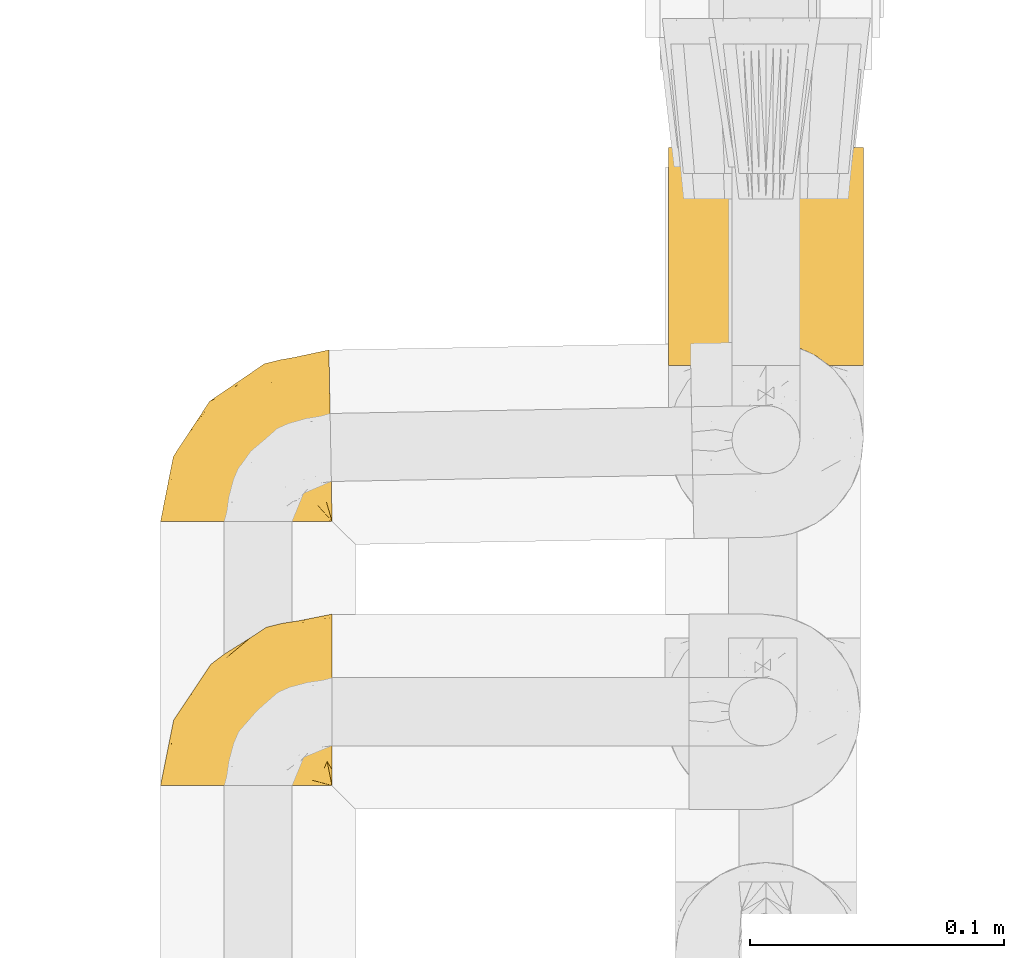
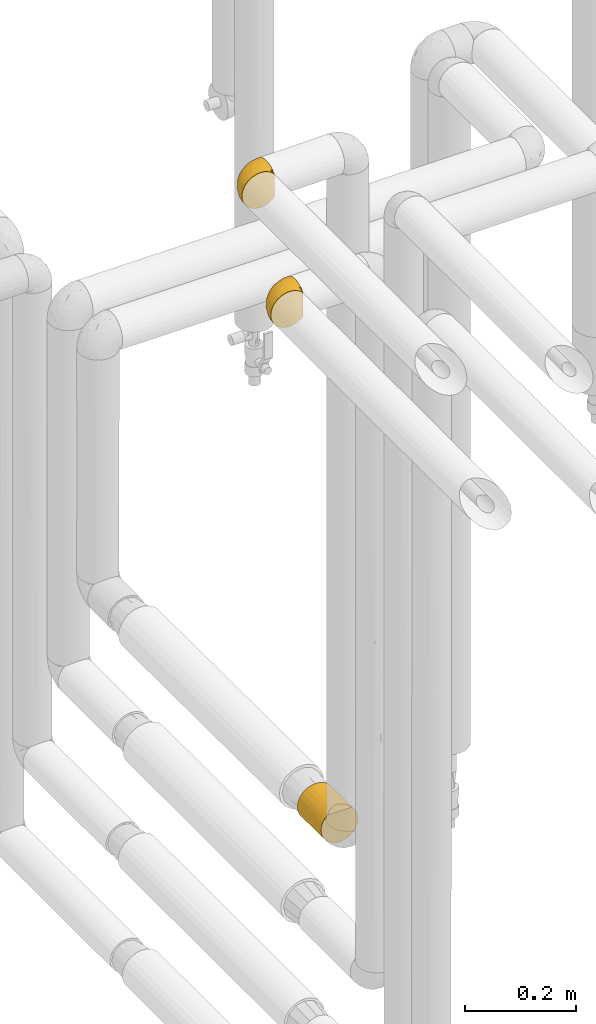
# One storey, part 70 of 827: 3 coverings.
"""IFC2X3 building model written with IfcOpenShell, lengths in millimetres."""

from ifc_helpers import new_model, entity, si_unit, converted_unit, derived_unit, direction, frame, origin, place, context, subcontext, project, spatial, faceted_brep, element, save


model = new_model("IFC2X3")

# Units and contexts
model_context = context("Model", 3, precision=0.01, world=origin(), true_north=direction((6.12303176911189e-17, 1.0)))
body_context = subcontext(model_context, "Body", "Model", "MODEL_VIEW")
ifc_project = project(units=[si_unit("LENGTHUNIT", "METRE", prefix="MILLI"), si_unit("AREAUNIT", "SQUARE_METRE"), si_unit("VOLUMEUNIT", "CUBIC_METRE"), converted_unit("PLANEANGLEUNIT", "DEGREE", entity("IfcRatioMeasure", 0.0174532925199433), si_unit("PLANEANGLEUNIT", "RADIAN"), dimensions=[0, 0, 0, 0, 0, 0, 0]), si_unit("MASSUNIT", "GRAM", prefix="KILO"), derived_unit("MASSDENSITYUNIT", [(si_unit("MASSUNIT", "GRAM", prefix="KILO"), 1), (si_unit("LENGTHUNIT", "METRE"), -3)]), derived_unit("MOMENTOFINERTIAUNIT", [(si_unit("LENGTHUNIT", "METRE"), 4)]), si_unit("TIMEUNIT", "SECOND"), si_unit("FREQUENCYUNIT", "HERTZ"), si_unit("THERMODYNAMICTEMPERATUREUNIT", "DEGREE_CELSIUS"), derived_unit("THERMALTRANSMITTANCEUNIT", [(si_unit("MASSUNIT", "GRAM", prefix="KILO"), 1), (si_unit("THERMODYNAMICTEMPERATUREUNIT", "KELVIN"), -1), (si_unit("TIMEUNIT", "SECOND"), -3)]), derived_unit("VOLUMETRICFLOWRATEUNIT", [(si_unit("LENGTHUNIT", "METRE"), 3), (si_unit("TIMEUNIT", "SECOND"), -1)]), derived_unit("MASSFLOWRATEUNIT", [(si_unit("MASSUNIT", "GRAM", prefix="KILO"), 1), (si_unit("TIMEUNIT", "SECOND"), -1)]), derived_unit("ROTATIONALFREQUENCYUNIT", [(si_unit("TIMEUNIT", "SECOND"), -1)]), si_unit("ELECTRICCURRENTUNIT", "AMPERE"), si_unit("ELECTRICVOLTAGEUNIT", "VOLT"), si_unit("POWERUNIT", "WATT"), si_unit("FORCEUNIT", "NEWTON", prefix="KILO"), si_unit("ILLUMINANCEUNIT", "LUX"), si_unit("LUMINOUSFLUXUNIT", "LUMEN"), si_unit("LUMINOUSINTENSITYUNIT", "CANDELA"), derived_unit("USERDEFINED", [(si_unit("MASSUNIT", "GRAM", prefix="KILO"), -1), (si_unit("LENGTHUNIT", "METRE"), -2), (si_unit("TIMEUNIT", "SECOND"), 3), (si_unit("LUMINOUSFLUXUNIT", "LUMEN"), 1)]), derived_unit("LINEARVELOCITYUNIT", [(si_unit("LENGTHUNIT", "METRE"), 1), (si_unit("TIMEUNIT", "SECOND"), -1)]), si_unit("PRESSUREUNIT", "PASCAL"), derived_unit("USERDEFINED", [(si_unit("LENGTHUNIT", "METRE"), -2), (si_unit("MASSUNIT", "GRAM", prefix="KILO"), 1), (si_unit("TIMEUNIT", "SECOND"), -2)]), derived_unit("LINEARFORCEUNIT", [(si_unit("MASSUNIT", "GRAM", prefix="KILO"), 1), (si_unit("LENGTHUNIT", "METRE"), 1), (si_unit("TIMEUNIT", "SECOND"), -2), (si_unit("LENGTHUNIT", "METRE"), -1)]), derived_unit("PLANARFORCEUNIT", [(si_unit("MASSUNIT", "GRAM", prefix="KILO"), 1), (si_unit("LENGTHUNIT", "METRE"), 1), (si_unit("TIMEUNIT", "SECOND"), -2), (si_unit("LENGTHUNIT", "METRE"), -2)])], contexts=[model_context])

# Site, building, storey
site_placement = place(None, origin())
site = spatial("IfcSite", under=ifc_project, at=site_placement, CompositionType="ELEMENT")
building_placement = place(site_placement, origin())
building = spatial("IfcBuilding", under=site, at=building_placement, CompositionType="ELEMENT")
storey_placement = place(building_placement, frame((0.0, 0.0, 28200.0)))
storey = spatial("IfcBuildingStorey", under=building, at=storey_placement, Name="08", CompositionType="ELEMENT", Elevation=28200.0)

# Coverings
covering_1_placement = place(storey_placement, frame((17888.53, 10890.94, 1308.25)))
element("IfcCovering", 1, at=covering_1_placement, inside=storey, Name=":ADSK_", ObjectType=":ADSK_", PredefinedType="INSULATION", context=body_context, shape_type="Brep", body=[
    faceted_brep([(20.8, 1.6, 6.74), (30.06, 1.6, 2.9), (40.0, 1.6, 1.6), (49.93, 1.6, 2.9), (59.2, 1.6, 6.74), (67.15, 1.6, 12.84), (73.25, 1.6, 20.8), (77.09, 1.6, 30.06), (78.4, 1.6, 40.0), (77.51, 1.6, 48.2), (74.9, 1.6, 56.01), (70.68, 1.6, 63.08), (65.05, 1.6, 69.1), (14.94, 1.6, 69.1), (9.31, 1.6, 63.08), (5.09, 1.6, 56.01), (2.48, 1.6, 48.2), (1.6, 1.6, 40.0), (2.9, 1.6, 30.06), (6.74, 1.6, 20.8), (12.84, 1.6, 12.84), (20.8, 87.5, 6.74), (12.84, 87.5, 12.84), (6.74, 87.5, 20.8), (2.9, 87.5, 30.06), (1.6, 87.5, 40.0), (2.9, 87.5, 49.93), (6.74, 87.5, 59.2), (12.84, 87.5, 67.15), (20.8, 87.5, 73.25), (30.06, 87.5, 77.09), (40.0, 87.5, 78.4), (49.93, 87.5, 77.09), (59.2, 87.5, 73.25), (67.15, 87.5, 67.15), (73.25, 87.5, 59.2), (77.09, 87.5, 49.93), (78.4, 87.5, 40.0), (77.09, 87.5, 30.06), (73.25, 87.5, 20.8), (67.15, 87.5, 12.84), (59.2, 87.5, 6.74), (49.93, 87.5, 2.9), (40.0, 87.5, 1.6), (30.06, 87.5, 2.9), (53.36, 8.5, 76.0), (46.78, 10.29, 77.79), (40.0, 10.9, 78.4), (59.51, 5.57, 73.07), (33.21, 10.29, 77.79), (26.63, 8.5, 76.0), (20.48, 5.57, 73.07)], [[[0, 1, 2, 3, 4, 5, 6, 7, 8, 9, 10, 11, 12, 13, 14, 15, 16, 17, 18, 19, 20]], [[21, 22, 23, 24, 25, 26, 27, 28, 29, 30, 31, 32, 33, 34, 35, 36, 37, 38, 39, 40, 41, 42, 43, 44]], [[24, 23, 19, 18]], [[25, 24, 18, 17]], [[23, 22, 20, 19]], [[1, 0, 21, 44]], [[2, 1, 44, 43]], [[22, 21, 0, 20]], [[3, 2, 43, 42]], [[4, 3, 42, 41]], [[41, 40, 5, 4]], [[7, 6, 39, 38]], [[8, 7, 38, 37]], [[40, 39, 6, 5]], [[9, 37, 36]], [[10, 36, 35]], [[11, 35, 34]], [[8, 37, 9]], [[9, 36, 10]], [[35, 11, 10]], [[34, 12, 11]], [[45, 33, 32]], [[32, 31, 46]], [[47, 46, 31]], [[48, 12, 33]], [[46, 45, 32]], [[48, 33, 45]], [[33, 12, 34]], [[49, 47, 31]], [[49, 31, 30]], [[50, 30, 29]], [[50, 49, 30]], [[13, 51, 29]], [[50, 29, 51]], [[29, 28, 13]], [[14, 28, 27]], [[15, 27, 26]], [[16, 26, 25]], [[14, 27, 15]], [[15, 26, 16]], [[25, 17, 16]], [[28, 14, 13]], [[45, 46, 47, 49, 50, 51, 13, 12, 48]]]),
])
covering_2_placement = place(storey_placement, frame((17688.48, 10829.62, 2810.08)))
element("IfcCovering", 2, at=covering_2_placement, inside=storey, Name=":ADSK_", ObjectType=":ADSK_", PredefinedType="INSULATION", context=body_context, shape_type="Brep", body=[
    faceted_brep([(62.89, 1.6, 70.97), (55.87, 1.6, 75.09), (48.14, 1.6, 77.64), (40.05, 1.6, 78.5), (31.49, 1.6, 77.53), (23.36, 1.6, 74.69), (16.07, 1.6, 70.11), (9.98, 1.6, 64.02), (5.4, 1.6, 56.73), (2.56, 1.6, 48.6), (1.6, 1.6, 40.05), (2.56, 1.6, 31.49), (5.4, 1.6, 23.36), (9.99, 1.6, 16.07), (16.07, 1.6, 9.98), (23.36, 1.6, 5.4), (31.49, 1.6, 2.56), (40.04, 1.6, 1.6), (48.14, 1.6, 2.46), (55.87, 1.6, 5.01), (62.9, 1.6, 9.12), (68.89, 1.6, 14.62), (68.89, 1.6, 16.82), (68.89, 1.6, 18.55), (68.89, 1.6, 20.52), (68.89, 1.6, 22.49), (68.89, 1.6, 24.45), (68.89, 1.6, 26.42), (68.89, 1.6, 28.39), (68.89, 1.6, 30.35), (68.89, 1.6, 32.55), (68.89, 1.6, 34.74), (68.89, 1.6, 36.94), (68.89, 1.6, 39.13), (68.89, 1.6, 41.33), (68.89, 1.6, 43.52), (68.89, 1.6, 45.71), (68.89, 1.6, 47.91), (68.89, 1.6, 50.1), (68.89, 1.6, 52.3), (68.89, 1.6, 54.49), (68.89, 1.6, 56.69), (68.89, 1.6, 58.88), (68.9, 1.6, 61.08), (68.9, 1.6, 63.27), (68.9, 1.6, 65.46), (69.14, 1.85, 14.62), (69.03, 7.85, 9.12), (68.9, 14.87, 5.0), (68.76, 22.6, 2.46), (68.61, 30.7, 1.6), (68.43, 40.65, 2.91), (68.26, 49.92, 6.75), (68.12, 57.88, 12.86), (68.01, 63.99, 20.82), (67.94, 67.83, 30.1), (67.92, 69.14, 40.05), (67.94, 67.83, 50.0), (68.01, 63.99, 59.27), (68.13, 57.88, 67.24), (68.27, 49.91, 73.35), (68.44, 40.64, 77.19), (68.62, 30.69, 78.5), (68.77, 22.6, 77.63), (68.91, 14.87, 75.09), (69.04, 7.85, 70.97), (69.14, 1.85, 65.46), (69.14, 1.85, 63.27), (69.14, 1.85, 62.29), (69.14, 1.85, 60.7), (69.14, 1.85, 59.11), (69.14, 1.85, 57.52), (69.14, 1.85, 55.93), (69.14, 1.85, 54.34), (69.14, 1.85, 52.75), (69.14, 1.85, 51.16), (69.14, 1.85, 49.58), (69.14, 1.85, 47.99), (69.14, 1.85, 46.4), (69.14, 1.85, 44.81), (69.14, 1.85, 43.22), (69.14, 1.85, 41.63), (69.14, 1.85, 40.04), (69.14, 1.85, 38.45), (69.14, 1.85, 36.87), (69.14, 1.85, 35.28), (69.14, 1.85, 33.69), (69.14, 1.85, 32.1), (69.14, 1.85, 30.51), (69.14, 1.85, 28.92), (69.14, 1.85, 27.33), (69.14, 1.85, 25.37), (69.14, 1.85, 23.4), (69.14, 1.85, 21.2), (69.14, 1.85, 19.01), (69.14, 1.85, 16.82), (68.96, 1.77, 42.33), (68.97, 1.78, 44.01), (68.97, 1.78, 45.71), (68.97, 1.78, 47.19), (68.95, 1.77, 23.63), (68.96, 1.77, 25.15), (68.98, 1.78, 61.34), (68.97, 1.79, 22.09), (68.97, 1.78, 29.72), (68.98, 1.79, 56.73), (68.97, 1.78, 55.16), (68.97, 1.78, 37.66), (68.94, 1.74, 64.12), (68.97, 1.79, 28.13), (68.97, 1.78, 26.64), (68.96, 1.77, 31.43), (68.96, 1.78, 16.15), (68.97, 1.78, 40.79), (68.97, 1.79, 39.29), (68.97, 1.78, 50.45), (68.96, 1.78, 17.69), (68.96, 1.77, 19.15), (68.97, 1.77, 62.78), (68.97, 1.78, 58.38), (68.96, 1.77, 59.9), (68.97, 1.77, 65.46), (68.95, 1.72, 65.46), (68.92, 1.66, 65.46), (68.96, 1.78, 14.62), (69.02, 1.8, 14.62), (68.97, 1.79, 34.46), (68.97, 1.78, 32.95), (68.97, 1.78, 20.63), (68.96, 1.77, 53.51), (68.98, 1.78, 51.96), (68.96, 1.77, 48.83), (69.08, 1.82, 65.46), (68.92, 1.67, 14.62), (68.94, 1.72, 14.62), (68.96, 1.77, 35.99), (69.07, 1.82, 14.62), (66.88, 9.37, 7.84), (63.06, 17.56, 3.52), (64.47, 7.46, 8.24), (43.85, 16.0, 1.6), (52.06, 12.48, 2.63), (53.09, 7.39, 3.53), (61.45, 28.66, 1.6), (61.35, 13.61, 4.55), (57.66, 12.88, 3.86), (56.0, 19.11, 2.28), (62.89, 29.07, 1.6), (65.23, 9.11, 7.6), (62.85, 5.67, 8.24), (61.33, 3.72, 7.84), (41.95, 8.8, 1.6), (49.07, 21.31, 1.6), (54.29, 26.62, 1.6), (57.3, 8.24, 4.87), (41.56, 7.35, 1.6), (13.77, 37.74, 29.67), (5.81, 17.86, 27.35), (6.62, 27.16, 40.05), (58.22, 36.84, 2.4), (51.02, 33.94, 2.43), (60.79, 44.61, 4.52), (51.7, 41.8, 4.53), (48.39, 65.17, 32.88), (54.36, 66.22, 40.05), (20.19, 37.34, 18.02), (21.9, 45.75, 25.43), (12.61, 26.21, 19.59), (51.34, 63.72, 25.34), (4.27, 15.21, 40.05), (57.81, 60.12, 16.64), (54.67, 52.08, 9.54), (45.47, 56.3, 16.64), (41.71, 26.0, 2.36), (34.68, 22.53, 3.27), (28.66, 11.99, 3.75), (20.48, 10.96, 7.49), (14.63, 15.59, 12.86), (23.71, 21.38, 7.49), (28.82, 40.87, 12.86), (34.51, 38.81, 8.33), (27.85, 31.74, 8.53), (19.45, 28.04, 12.86), (8.6, 13.24, 19.59), (41.58, 45.46, 9.01), (23.02, 49.92, 32.49), (31.29, 54.92, 27.35), (31.7, 56.29, 40.05), (13.78, 38.05, 40.05), (20.95, 48.93, 40.05), (29.33, 48.62, 19.52), (40.95, 33.74, 4.1), (36.66, 49.06, 14.14), (42.45, 63.65, 40.05), (27.85, 31.75, 71.56), (34.69, 22.54, 76.82), (40.96, 33.74, 75.99), (48.39, 65.17, 47.22), (23.02, 49.91, 47.61), (13.76, 37.72, 50.43), (21.88, 45.72, 54.67), (31.27, 54.9, 52.76), (51.34, 63.72, 54.76), (57.82, 60.11, 63.46), (54.68, 52.07, 70.55), (23.71, 21.38, 72.6), (20.48, 10.95, 72.6), (28.66, 11.99, 76.34), (60.79, 44.61, 75.57), (58.23, 36.83, 77.7), (41.57, 7.34, 78.5), (29.31, 48.6, 60.58), (5.81, 17.86, 52.75), (20.19, 37.34, 62.07), (14.62, 15.59, 67.23), (12.61, 26.21, 60.5), (8.6, 13.24, 60.5), (19.45, 28.04, 67.23), (43.86, 15.99, 78.5), (51.03, 33.93, 77.66), (54.3, 26.62, 78.5), (41.58, 45.45, 71.08), (51.71, 41.79, 75.57), (41.96, 8.79, 78.5), (45.48, 56.3, 63.46), (61.46, 28.65, 78.5), (62.9, 29.06, 78.5), (28.82, 40.88, 67.23), (36.68, 49.07, 65.95), (41.72, 26.0, 77.74), (49.08, 21.31, 78.5), (34.51, 38.82, 71.76), (63.07, 17.55, 76.57), (66.89, 9.34, 72.23), (69.02, 1.8, 65.46), (63.47, 7.9, 72.5), (63.21, 6.16, 71.85), (53.08, 7.38, 76.57), (57.96, 18.47, 77.46), (61.43, 12.46, 75.11), (65.34, 7.76, 71.68), (61.34, 3.72, 72.25), (57.67, 12.87, 76.23), (51.4, 14.42, 77.81), (57.0, 9.16, 75.54), (61.57, 5.37, 72.49)], [[[0, 1, 2, 3, 4, 5, 6, 7, 8, 9, 10, 11, 12, 13, 14, 15, 16, 17, 18, 19, 20, 21, 22, 23, 24, 25, 26, 27, 28, 29, 30, 31, 32, 33, 34, 35, 36, 37, 38, 39, 40, 41, 42, 43, 44, 45]], [[46, 47, 48, 49, 50, 51, 52, 53, 54, 55, 56, 57, 58, 59, 60, 61, 62, 63, 64, 65, 66, 67, 68, 69, 70, 71, 72, 73, 74, 75, 76, 77, 78, 79, 80, 81, 82, 83, 84, 85, 86, 87, 88, 89, 90, 91, 92, 93, 94, 95]], [[96, 97, 35]], [[98, 99, 36]], [[100, 101, 26]], [[69, 68, 102]], [[25, 24, 103]], [[29, 28, 104]], [[25, 103, 100]], [[72, 105, 106]], [[84, 83, 107]], [[89, 88, 104]], [[108, 67, 66]], [[109, 110, 90]], [[111, 29, 104]], [[112, 22, 21]], [[113, 114, 82]], [[109, 28, 27]], [[115, 39, 38]], [[105, 41, 106]], [[111, 30, 29]], [[23, 116, 117]], [[97, 96, 80]], [[67, 108, 118]], [[105, 71, 119]], [[98, 36, 97]], [[102, 120, 69]], [[108, 121, 122, 123, 45]], [[112, 95, 116]], [[22, 116, 23]], [[94, 117, 116]], [[118, 68, 67]], [[43, 118, 44]], [[112, 124, 125]], [[22, 112, 116]], [[70, 120, 119]], [[44, 118, 108]], [[120, 43, 42]], [[120, 42, 119]], [[120, 70, 69]], [[126, 127, 86]], [[117, 94, 128]], [[118, 43, 102]], [[129, 130, 74]], [[77, 131, 99]], [[116, 95, 94]], [[44, 108, 45]], [[108, 66, 132]], [[95, 112, 46]], [[112, 21, 133, 134, 124]], [[105, 72, 71]], [[119, 42, 41]], [[71, 70, 119]], [[40, 106, 41]], [[41, 105, 119]], [[40, 129, 106]], [[74, 73, 129]], [[106, 129, 73]], [[131, 115, 38]], [[129, 40, 39]], [[73, 72, 106]], [[75, 74, 130]], [[115, 75, 130]], [[130, 39, 115]], [[39, 130, 129]], [[115, 76, 75]], [[76, 115, 131]], [[77, 99, 78]], [[37, 131, 38]], [[77, 76, 131]], [[37, 36, 99]], [[98, 78, 99]], [[37, 99, 131]], [[80, 79, 97]], [[79, 98, 97]], [[79, 78, 98]], [[113, 96, 34]], [[36, 35, 97]], [[113, 34, 33]], [[81, 80, 96]], [[34, 96, 35]], [[96, 113, 81]], [[82, 81, 113]], [[33, 114, 113]], [[84, 107, 135]], [[107, 32, 135]], [[114, 33, 107]], [[32, 107, 33]], [[126, 86, 85]], [[135, 32, 31]], [[114, 83, 82]], [[83, 114, 107]], [[85, 84, 135]], [[109, 89, 104]], [[89, 109, 90]], [[111, 87, 127]], [[127, 126, 31]], [[88, 111, 104]], [[30, 111, 127]], [[27, 110, 109]], [[28, 109, 104]], [[110, 91, 90]], [[100, 92, 101]], [[110, 27, 101]], [[91, 110, 101]], [[117, 24, 23]], [[111, 88, 87]], [[103, 24, 128]], [[30, 127, 31]], [[86, 127, 87]], [[126, 135, 31]], [[135, 126, 85]], [[120, 102, 43]], [[118, 102, 68]], [[91, 101, 92]], [[26, 101, 27]], [[93, 92, 103]], [[100, 26, 25]], [[100, 103, 92]], [[128, 93, 103]], [[93, 128, 94]], [[128, 24, 117]], [[136, 137, 47]], [[48, 137, 138]], [[139, 125, 124]], [[140, 141, 142]], [[143, 49, 138]], [[144, 139, 145]], [[48, 138, 49]], [[138, 144, 146]], [[49, 143, 147, 50]], [[136, 125, 148]], [[19, 18, 142]], [[149, 145, 139]], [[148, 139, 144]], [[133, 150, 149]], [[150, 19, 142]], [[21, 20, 133]], [[18, 151, 142]], [[124, 149, 139]], [[141, 152, 145]], [[19, 150, 20]], [[20, 150, 133]], [[47, 46, 136]], [[138, 153, 143]], [[137, 48, 47]], [[125, 139, 148]], [[149, 124, 134, 133]], [[141, 154, 142]], [[144, 145, 146]], [[148, 138, 137]], [[146, 152, 153]], [[152, 146, 145]], [[138, 146, 153]], [[138, 148, 144]], [[148, 137, 136]], [[18, 17, 155, 151]], [[151, 140, 142]], [[150, 142, 154]], [[152, 141, 140]], [[154, 145, 149]], [[145, 154, 141]], [[150, 154, 149]], [[156, 157, 158]], [[159, 153, 160]], [[161, 52, 51]], [[162, 161, 159]], [[55, 163, 164]], [[165, 156, 166]], [[155, 17, 16]], [[167, 157, 156]], [[163, 55, 168]], [[157, 11, 169]], [[170, 54, 53]], [[53, 52, 171]], [[168, 55, 54]], [[54, 170, 168]], [[170, 171, 172]], [[152, 173, 160]], [[174, 140, 175]], [[155, 16, 175]], [[176, 177, 178]], [[177, 14, 13]], [[175, 140, 151, 155]], [[175, 16, 15]], [[176, 175, 15]], [[179, 180, 181]], [[175, 178, 174]], [[182, 177, 167]], [[179, 182, 165]], [[177, 182, 178]], [[13, 12, 183]], [[157, 12, 11]], [[158, 157, 169]], [[167, 183, 157]], [[172, 171, 184]], [[183, 177, 13]], [[185, 186, 166]], [[14, 176, 15]], [[187, 186, 185]], [[185, 188, 189]], [[165, 190, 179]], [[51, 50, 147]], [[161, 171, 52]], [[184, 171, 162]], [[172, 186, 168]], [[184, 191, 180]], [[178, 182, 181]], [[174, 191, 173]], [[11, 10, 169]], [[157, 183, 12]], [[177, 183, 167]], [[177, 176, 14]], [[175, 176, 178]], [[191, 184, 162]], [[179, 190, 192]], [[160, 162, 159]], [[174, 178, 181]], [[164, 163, 193]], [[164, 56, 55]], [[186, 163, 168]], [[165, 182, 167]], [[174, 173, 140]], [[181, 182, 179]], [[167, 156, 165]], [[190, 166, 186]], [[186, 172, 190]], [[192, 184, 180]], [[179, 192, 180]], [[174, 181, 191]], [[165, 166, 190]], [[188, 185, 156]], [[156, 185, 166]], [[193, 163, 187]], [[185, 189, 187]], [[163, 186, 187]], [[191, 181, 180]], [[190, 172, 192]], [[172, 184, 192]], [[159, 51, 147]], [[171, 161, 162]], [[51, 159, 161]], [[159, 147, 143, 153]], [[152, 160, 153]], [[191, 162, 160]], [[171, 170, 53]], [[168, 170, 172]], [[156, 158, 188]], [[160, 173, 191]], [[140, 173, 152]], [[194, 195, 196]], [[193, 197, 164]], [[198, 199, 200]], [[201, 202, 197]], [[59, 203, 204]], [[187, 189, 198]], [[205, 206, 207]], [[5, 4, 207]], [[61, 208, 209]], [[4, 210, 207]], [[59, 204, 60]], [[4, 3, 210]], [[164, 197, 57]], [[208, 61, 60]], [[200, 211, 201]], [[58, 57, 202]], [[158, 212, 199]], [[213, 211, 200]], [[214, 215, 216]], [[7, 6, 214]], [[203, 59, 58]], [[212, 8, 216]], [[212, 169, 9]], [[6, 5, 206]], [[207, 206, 5]], [[8, 212, 9]], [[215, 214, 217]], [[205, 207, 195]], [[207, 218, 195]], [[209, 219, 220]], [[204, 221, 222]], [[206, 214, 6]], [[199, 212, 215]], [[217, 214, 205]], [[213, 215, 217]], [[8, 7, 216]], [[198, 188, 199]], [[207, 210, 223, 218]], [[203, 202, 224]], [[209, 220, 225, 226]], [[226, 62, 61]], [[201, 224, 202]], [[211, 227, 228]], [[208, 204, 222]], [[229, 218, 230]], [[196, 222, 221]], [[169, 212, 158]], [[169, 10, 9]], [[214, 206, 205]], [[214, 216, 7]], [[212, 216, 215]], [[224, 221, 204]], [[217, 194, 227]], [[231, 227, 194]], [[195, 229, 196]], [[57, 56, 164]], [[201, 187, 198]], [[57, 197, 202]], [[194, 217, 205]], [[219, 230, 220]], [[213, 217, 227]], [[195, 194, 205]], [[231, 221, 228]], [[213, 227, 211]], [[199, 215, 213]], [[227, 231, 228]], [[224, 201, 211]], [[198, 200, 201]], [[213, 200, 199]], [[197, 187, 201]], [[218, 229, 195]], [[187, 197, 193]], [[194, 196, 231]], [[196, 221, 231]], [[221, 224, 228]], [[224, 211, 228]], [[204, 208, 60]], [[209, 208, 222]], [[209, 222, 219]], [[61, 209, 226]], [[222, 196, 219]], [[219, 196, 229]], [[202, 203, 58]], [[204, 203, 224]], [[188, 198, 189]], [[188, 158, 199]], [[219, 229, 230]], [[63, 225, 232]], [[225, 220, 232]], [[63, 62, 226, 225]], [[233, 64, 232]], [[121, 234, 235]], [[236, 122, 121]], [[237, 218, 223]], [[63, 232, 64]], [[132, 66, 65]], [[232, 238, 239]], [[237, 223, 2]], [[240, 132, 233]], [[233, 132, 65]], [[1, 237, 2]], [[220, 238, 232]], [[0, 123, 241]], [[2, 223, 210, 3]], [[235, 234, 240]], [[238, 230, 242]], [[243, 237, 244]], [[245, 236, 244]], [[0, 45, 123]], [[123, 122, 245]], [[241, 1, 0]], [[1, 241, 237]], [[240, 239, 235]], [[244, 236, 242]], [[122, 236, 245]], [[244, 242, 243]], [[245, 237, 241]], [[243, 230, 218]], [[230, 243, 242]], [[237, 243, 218]], [[237, 245, 244]], [[245, 241, 123]], [[230, 238, 220]], [[239, 238, 242]], [[235, 242, 236]], [[232, 239, 240]], [[242, 235, 239]], [[121, 235, 236]], [[64, 233, 65]], [[132, 240, 234]], [[232, 240, 233]], [[112, 125, 136]], [[112, 136, 46]], [[108, 132, 234]], [[108, 234, 121]]]),
])
covering_3_placement = place(storey_placement, frame((17688.48, 10725.53, 2611.68)))
element("IfcCovering", 3, at=covering_3_placement, inside=storey, Name=":ADSK_", ObjectType=":ADSK_", PredefinedType="INSULATION", context=body_context, shape_type="Brep", body=[
    faceted_brep([(23.36, 1.6, 74.68), (16.07, 1.6, 70.1), (9.98, 1.6, 64.01), (5.4, 1.6, 56.72), (2.56, 1.6, 48.6), (1.6, 1.6, 40.05), (2.56, 1.6, 31.49), (5.41, 1.6, 23.36), (9.99, 1.6, 16.07), (16.08, 1.6, 9.98), (23.37, 1.6, 5.4), (31.49, 1.6, 2.56), (40.05, 1.6, 1.6), (48.15, 1.6, 2.46), (55.88, 1.6, 5.01), (62.9, 1.6, 9.13), (68.89, 1.6, 14.62), (68.89, 1.6, 16.82), (68.89, 1.6, 18.56), (68.89, 1.6, 20.52), (68.89, 1.6, 22.49), (68.89, 1.6, 24.46), (68.89, 1.6, 26.42), (68.89, 1.6, 28.39), (68.89, 1.6, 30.36), (68.89, 1.6, 32.55), (68.89, 1.6, 34.75), (68.89, 1.6, 36.94), (68.89, 1.6, 39.13), (68.89, 1.6, 41.33), (68.89, 1.6, 43.52), (68.89, 1.6, 45.72), (68.89, 1.6, 47.91), (68.89, 1.6, 50.11), (68.89, 1.6, 52.3), (68.89, 1.6, 54.49), (68.89, 1.6, 56.69), (68.89, 1.6, 58.88), (68.89, 1.6, 61.08), (68.89, 1.6, 63.27), (68.89, 1.6, 65.47), (62.89, 1.6, 70.97), (55.86, 1.6, 75.09), (48.13, 1.6, 77.64), (40.05, 1.6, 78.5), (31.49, 1.6, 77.53), (69.15, 1.85, 14.62), (69.15, 7.85, 9.12), (69.15, 14.87, 5.0), (69.15, 22.6, 2.46), (69.15, 30.7, 1.6), (69.15, 40.65, 2.91), (69.15, 49.92, 6.75), (69.15, 57.88, 12.86), (69.15, 63.99, 20.82), (69.15, 67.84, 30.09), (69.15, 69.15, 40.05), (69.15, 67.84, 50.0), (69.15, 63.99, 59.27), (69.15, 57.88, 67.23), (69.15, 49.92, 73.34), (69.15, 40.65, 77.19), (69.15, 30.7, 78.5), (69.15, 22.6, 77.63), (69.15, 14.87, 75.09), (69.15, 7.85, 70.97), (69.15, 1.85, 65.47), (69.15, 1.85, 63.27), (69.15, 1.85, 62.29), (69.15, 1.85, 60.7), (69.15, 1.85, 59.11), (69.15, 1.85, 57.52), (69.15, 1.85, 55.93), (69.15, 1.85, 54.34), (69.15, 1.85, 52.76), (69.15, 1.85, 51.17), (69.15, 1.85, 49.58), (69.15, 1.85, 47.99), (69.15, 1.85, 46.4), (69.15, 1.85, 44.81), (69.15, 1.85, 43.22), (69.15, 1.85, 41.63), (69.15, 1.85, 40.05), (69.15, 1.85, 38.46), (69.15, 1.85, 36.87), (69.15, 1.85, 35.28), (69.15, 1.85, 33.69), (69.15, 1.85, 32.1), (69.15, 1.85, 30.51), (69.15, 1.85, 28.92), (69.15, 1.85, 27.33), (69.15, 1.85, 25.37), (69.15, 1.85, 23.4), (69.15, 1.85, 21.21), (69.15, 1.85, 19.01), (69.15, 1.85, 16.82), (68.96, 1.77, 42.32), (68.97, 1.78, 44.02), (68.97, 1.77, 47.13), (68.97, 1.77, 48.74), (68.95, 1.76, 23.57), (68.96, 1.77, 25.13), (68.98, 1.79, 61.34), (68.97, 1.78, 22.02), (68.97, 1.78, 29.72), (68.98, 1.78, 56.73), (68.97, 1.78, 55.14), (68.97, 1.78, 37.66), (68.94, 1.74, 64.12), (68.98, 1.78, 28.13), (68.98, 1.78, 26.62), (68.96, 1.77, 31.46), (68.97, 1.78, 16.16), (68.98, 1.78, 39.16), (68.98, 1.78, 50.37), (68.97, 1.77, 17.69), (68.96, 1.77, 19.17), (68.97, 1.77, 62.78), (68.97, 1.78, 58.35), (68.98, 1.78, 45.53), (68.96, 1.77, 59.91), (68.97, 1.77, 65.47), (68.94, 1.72, 65.47), (68.92, 1.66, 65.47), (68.97, 1.77, 14.62), (69.02, 1.8, 14.62), (69.08, 1.82, 14.62), (68.98, 1.79, 20.59), (68.97, 1.78, 32.99), (68.98, 1.79, 34.48), (68.97, 1.78, 51.91), (69.08, 1.82, 65.47), (69.02, 1.8, 65.47), (68.96, 1.76, 53.48), (68.92, 1.66, 14.62), (68.94, 1.72, 14.62), (68.97, 1.78, 40.77), (68.96, 1.77, 35.97), (67.02, 9.41, 7.84), (63.33, 17.65, 3.53), (64.61, 7.41, 8.32), (49.27, 21.47, 1.6), (51.4, 15.21, 2.19), (43.94, 16.15, 1.6), (61.87, 28.75, 1.6), (61.54, 13.67, 4.57), (57.95, 12.79, 3.96), (56.12, 19.18, 2.28), (63.4, 29.16, 1.6), (65.41, 9.04, 7.69), (53.1, 7.41, 3.53), (63.04, 5.74, 8.32), (61.33, 3.72, 7.84), (41.99, 8.87, 1.6), (54.6, 26.8, 1.6), (56.6, 9.53, 4.34), (41.58, 7.34, 1.6), (13.72, 37.63, 29.63), (5.82, 17.92, 27.34), (6.74, 27.45, 40.05), (58.82, 37.01, 2.39), (51.58, 34.22, 2.43), (42.09, 45.87, 9.07), (46.12, 56.57, 16.64), (55.56, 52.31, 9.54), (52.38, 42.07, 4.52), (61.54, 44.74, 4.52), (23.76, 21.49, 7.49), (20.5, 11.02, 7.49), (14.64, 15.64, 12.85), (41.77, 26.02, 2.35), (16.28, 36.59, 22.66), (49.4, 65.49, 32.9), (52.34, 63.99, 25.33), (4.3, 15.2, 40.05), (58.67, 60.27, 16.64), (25.26, 45.25, 19.99), (20.17, 35.21, 16.37), (34.7, 22.52, 3.26), (28.67, 12.03, 3.75), (8.62, 13.32, 19.58), (33.37, 35.9, 7.5), (41.35, 33.87, 4.04), (17.15, 25.73, 13.94), (12.68, 26.34, 19.58), (21.47, 46.78, 28.21), (41.11, 59.54, 24.75), (37.53, 60.18, 31.42), (30.64, 53.93, 26.2), (26.66, 53.36, 33.36), (21.38, 49.36, 40.05), (14.06, 38.4, 40.05), (55.54, 66.44, 40.05), (35.17, 50.09, 16.14), (29.04, 41.08, 12.85), (24.34, 31.14, 10.47), (29.33, 28.19, 6.49), (43.3, 64.0, 40.05), (32.34, 56.68, 40.05), (57.75, 43.9, 75.57), (49.41, 65.46, 47.37), (27.85, 52.22, 52.91), (13.7, 37.61, 50.46), (14.63, 15.64, 67.23), (8.61, 13.31, 60.5), (48.85, 50.02, 70.55), (54.13, 59.28, 63.45), (37.84, 53.05, 62.61), (23.75, 21.48, 72.6), (20.49, 11.01, 72.6), (28.66, 12.03, 76.34), (20.83, 41.02, 59.34), (55.15, 35.39, 77.76), (54.6, 26.8, 78.5), (61.87, 28.75, 78.5), (41.58, 7.34, 78.5), (57.58, 65.81, 53.16), (59.91, 53.28, 70.55), (36.94, 59.8, 48.88), (45.72, 61.82, 54.76), (5.82, 17.91, 52.74), (37.91, 41.4, 71.93), (50.18, 40.48, 75.79), (12.67, 26.34, 60.5), (49.29, 31.68, 77.86), (42.64, 27.68, 77.64), (43.94, 16.15, 78.5), (49.27, 21.47, 78.5), (19.45, 28.05, 67.23), (34.7, 22.54, 76.82), (41.99, 8.87, 78.5), (62.29, 37.3, 77.8), (29.01, 41.07, 67.23), (31.47, 32.24, 73.2), (37.18, 47.4, 67.66), (43.45, 35.77, 75.99), (63.33, 17.65, 76.57), (67.23, 11.06, 73.21), (66.07, 8.55, 71.93), (65.22, 6.63, 71.07), (61.99, 12.77, 75.09), (57.95, 12.79, 76.13), (53.09, 7.41, 76.57), (56.84, 18.97, 77.69), (61.33, 3.72, 72.26), (63.06, 5.76, 71.77), (51.41, 15.21, 77.9), (56.61, 9.52, 75.75)], [[[0, 1, 2, 3, 4, 5, 6, 7, 8, 9, 10, 11, 12, 13, 14, 15, 16, 17, 18, 19, 20, 21, 22, 23, 24, 25, 26, 27, 28, 29, 30, 31, 32, 33, 34, 35, 36, 37, 38, 39, 40, 41, 42, 43, 44, 45]], [[46, 47, 48, 49, 50, 51, 52, 53, 54, 55, 56, 57, 58, 59, 60, 61, 62, 63, 64, 65, 66, 67, 68, 69, 70, 71, 72, 73, 74, 75, 76, 77, 78, 79, 80, 81, 82, 83, 84, 85, 86, 87, 88, 89, 90, 91, 92, 93, 94, 95]], [[96, 97, 30]], [[98, 77, 99]], [[100, 101, 21]], [[69, 68, 102]], [[20, 19, 103]], [[24, 23, 104]], [[20, 103, 100]], [[72, 105, 106]], [[84, 83, 107]], [[89, 88, 104]], [[108, 67, 66]], [[109, 110, 90]], [[111, 25, 24]], [[112, 17, 16]], [[82, 113, 83]], [[109, 23, 22]], [[114, 76, 75]], [[105, 36, 106]], [[104, 111, 24]], [[18, 115, 116]], [[97, 96, 80]], [[67, 108, 117]], [[105, 71, 118]], [[31, 97, 119]], [[102, 120, 69]], [[108, 121, 122, 123, 40]], [[112, 95, 115]], [[17, 115, 18]], [[94, 116, 115]], [[117, 68, 67]], [[38, 117, 39]], [[112, 124, 125, 126, 46]], [[17, 112, 115]], [[70, 120, 118]], [[39, 117, 108]], [[120, 38, 37]], [[120, 37, 118]], [[120, 70, 69]], [[116, 94, 127]], [[128, 86, 129]], [[117, 38, 102]], [[74, 130, 75]], [[99, 33, 32]], [[115, 95, 94]], [[39, 108, 40]], [[108, 66, 131, 132, 121]], [[105, 72, 71]], [[118, 37, 36]], [[71, 70, 118]], [[35, 106, 36]], [[36, 105, 118]], [[35, 133, 106]], [[74, 73, 133]], [[106, 133, 73]], [[99, 114, 33]], [[133, 35, 34]], [[73, 72, 106]], [[95, 112, 46]], [[112, 16, 134, 135, 124]], [[130, 114, 75]], [[99, 76, 114]], [[114, 130, 33]], [[34, 33, 130]], [[78, 77, 98]], [[98, 119, 78]], [[130, 133, 34]], [[133, 130, 74]], [[79, 97, 80]], [[98, 99, 32]], [[98, 32, 31]], [[77, 76, 99]], [[97, 79, 119]], [[136, 96, 29]], [[30, 97, 31]], [[136, 29, 28]], [[81, 80, 96]], [[29, 96, 30]], [[31, 119, 98]], [[119, 79, 78]], [[96, 136, 81]], [[82, 81, 136]], [[113, 107, 83]], [[84, 107, 137]], [[107, 27, 137]], [[113, 28, 107]], [[27, 107, 28]], [[85, 84, 137]], [[137, 27, 26]], [[113, 136, 28]], [[136, 113, 82]], [[109, 89, 104]], [[86, 85, 129]], [[89, 109, 90]], [[111, 87, 128]], [[26, 129, 137]], [[88, 111, 104]], [[25, 111, 128]], [[22, 110, 109]], [[23, 109, 104]], [[110, 91, 90]], [[100, 92, 101]], [[110, 22, 101]], [[91, 110, 101]], [[116, 19, 18]], [[111, 88, 87]], [[127, 103, 19]], [[25, 128, 26]], [[86, 128, 87]], [[128, 129, 26]], [[137, 129, 85]], [[120, 102, 38]], [[117, 102, 68]], [[91, 101, 92]], [[21, 101, 22]], [[93, 92, 103]], [[100, 21, 20]], [[100, 103, 92]], [[127, 93, 103]], [[93, 127, 94]], [[116, 127, 19]], [[126, 138, 47]], [[48, 138, 139]], [[140, 125, 124]], [[141, 142, 143]], [[144, 49, 139]], [[145, 140, 146]], [[48, 139, 49]], [[139, 145, 147]], [[49, 144, 148, 50]], [[126, 125, 149]], [[14, 13, 150]], [[151, 146, 140]], [[149, 140, 145]], [[152, 151, 135]], [[152, 14, 150]], [[16, 15, 134]], [[13, 153, 150]], [[124, 151, 140]], [[141, 147, 142]], [[14, 152, 15]], [[15, 152, 134]], [[47, 46, 126]], [[139, 154, 144]], [[138, 48, 47]], [[125, 140, 149]], [[135, 134, 152]], [[146, 155, 142]], [[145, 146, 147]], [[149, 139, 138]], [[147, 141, 154]], [[147, 146, 142]], [[139, 147, 154]], [[139, 149, 145]], [[149, 138, 126]], [[155, 146, 151]], [[150, 143, 142]], [[152, 155, 151]], [[150, 142, 155]], [[13, 12, 156, 153]], [[153, 143, 150]], [[152, 150, 155]], [[151, 124, 135]], [[157, 158, 159]], [[160, 154, 161]], [[162, 163, 164]], [[165, 166, 160]], [[167, 168, 169]], [[141, 170, 161]], [[156, 12, 11]], [[158, 157, 171]], [[172, 55, 173]], [[158, 6, 174]], [[175, 54, 53]], [[52, 166, 164]], [[52, 164, 53]], [[54, 175, 173]], [[166, 52, 51]], [[176, 177, 171]], [[178, 143, 179]], [[156, 11, 179]], [[8, 7, 180]], [[169, 9, 8]], [[179, 143, 153, 156]], [[179, 11, 10]], [[168, 179, 10]], [[181, 162, 182]], [[179, 167, 178]], [[183, 184, 177]], [[183, 169, 184]], [[176, 171, 185]], [[172, 186, 187]], [[158, 7, 6]], [[159, 158, 174]], [[184, 180, 158]], [[54, 173, 55]], [[180, 169, 8]], [[188, 189, 187]], [[9, 168, 10]], [[186, 188, 187]], [[190, 157, 159, 191]], [[55, 172, 192]], [[176, 193, 194]], [[161, 170, 182]], [[162, 164, 165]], [[175, 164, 163]], [[51, 50, 148]], [[167, 195, 196]], [[178, 182, 170]], [[6, 5, 174]], [[158, 180, 7]], [[169, 180, 184]], [[169, 168, 9]], [[179, 168, 167]], [[182, 162, 165]], [[162, 194, 193]], [[161, 165, 160]], [[195, 181, 196]], [[192, 172, 197]], [[192, 56, 55]], [[189, 190, 198]], [[198, 197, 187]], [[172, 187, 197]], [[185, 189, 188]], [[198, 187, 189]], [[186, 172, 173]], [[173, 163, 186]], [[193, 186, 163]], [[176, 185, 188]], [[185, 157, 190]], [[188, 186, 193]], [[177, 176, 194]], [[188, 193, 176]], [[162, 193, 163]], [[195, 177, 194]], [[171, 177, 184]], [[181, 195, 194]], [[183, 167, 169]], [[162, 181, 194]], [[196, 182, 178]], [[158, 171, 184]], [[171, 157, 185]], [[177, 195, 183]], [[167, 183, 195]], [[182, 196, 181]], [[178, 170, 143]], [[178, 167, 196]], [[164, 175, 53]], [[173, 175, 163]], [[160, 51, 148]], [[164, 166, 165]], [[51, 160, 166]], [[160, 148, 144, 154]], [[141, 161, 154]], [[182, 165, 161]], [[190, 189, 185]], [[143, 170, 141]], [[60, 199, 61]], [[197, 200, 192]], [[201, 190, 202]], [[200, 57, 192]], [[203, 204, 2]], [[205, 206, 207]], [[208, 209, 210]], [[211, 207, 201]], [[212, 213, 214]], [[45, 215, 210]], [[216, 206, 58]], [[45, 44, 215]], [[59, 217, 60]], [[60, 217, 199]], [[0, 45, 210]], [[218, 201, 219]], [[202, 159, 220]], [[205, 221, 222]], [[223, 204, 203]], [[1, 203, 2]], [[57, 200, 216]], [[220, 3, 204]], [[220, 174, 4]], [[1, 0, 209]], [[212, 224, 213]], [[225, 226, 227]], [[228, 223, 203]], [[208, 210, 229]], [[210, 226, 229]], [[3, 220, 4]], [[58, 206, 59]], [[209, 203, 1]], [[202, 220, 223]], [[228, 203, 208]], [[202, 211, 201]], [[3, 2, 204]], [[202, 190, 191, 159]], [[210, 215, 230, 226]], [[199, 212, 231]], [[232, 233, 221]], [[233, 208, 229]], [[207, 206, 219]], [[217, 206, 205]], [[227, 224, 225]], [[233, 232, 228]], [[201, 207, 219]], [[234, 232, 221]], [[218, 219, 200]], [[202, 223, 211]], [[174, 220, 159]], [[174, 5, 4]], [[61, 231, 62]], [[220, 204, 223]], [[210, 209, 0]], [[203, 209, 208]], [[225, 233, 229]], [[224, 227, 213]], [[221, 233, 235]], [[57, 56, 192]], [[198, 218, 197]], [[200, 219, 216]], [[201, 198, 190]], [[197, 218, 200]], [[198, 201, 218]], [[206, 216, 219]], [[58, 57, 216]], [[231, 212, 214]], [[222, 212, 199]], [[228, 211, 223]], [[207, 211, 232]], [[62, 231, 214]], [[199, 231, 61]], [[233, 228, 208]], [[211, 228, 232]], [[222, 221, 235]], [[234, 205, 207]], [[206, 217, 59]], [[199, 217, 205]], [[205, 222, 199]], [[224, 222, 235]], [[222, 224, 212]], [[224, 235, 225]], [[233, 225, 235]], [[226, 225, 229]], [[205, 234, 221]], [[207, 232, 234]], [[63, 214, 236]], [[214, 213, 236]], [[214, 63, 62]], [[237, 236, 238]], [[238, 132, 131]], [[236, 237, 64]], [[239, 240, 241]], [[63, 236, 64]], [[131, 66, 65]], [[237, 131, 65]], [[242, 230, 43]], [[237, 65, 64]], [[239, 121, 132]], [[42, 242, 43]], [[241, 240, 243]], [[41, 123, 244]], [[43, 230, 215, 44]], [[244, 122, 245]], [[227, 246, 243]], [[241, 247, 245]], [[121, 239, 245]], [[41, 40, 123]], [[132, 238, 239]], [[244, 42, 41]], [[131, 237, 238]], [[240, 239, 238]], [[245, 239, 241]], [[247, 241, 246]], [[247, 244, 245]], [[238, 236, 240]], [[243, 236, 213]], [[236, 243, 240]], [[227, 226, 246]], [[243, 213, 227]], [[242, 246, 226]], [[243, 246, 241]], [[246, 242, 247]], [[244, 247, 242]], [[242, 226, 230]], [[42, 244, 242]], [[122, 244, 123]], [[122, 121, 245]]]),
])

save(model, "model.ifc")
